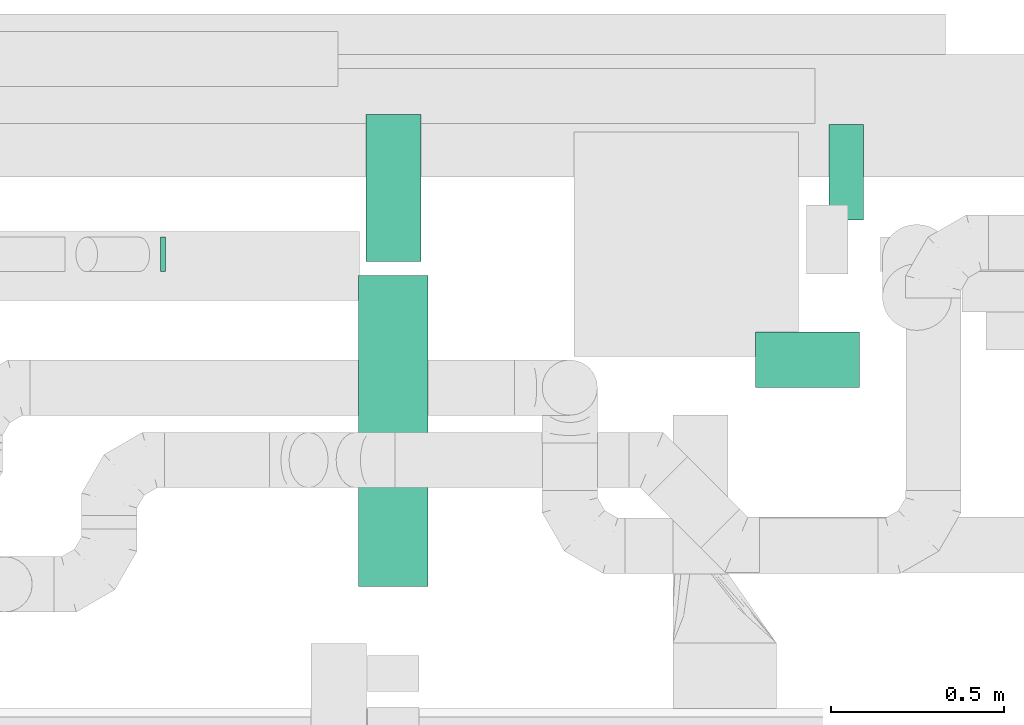
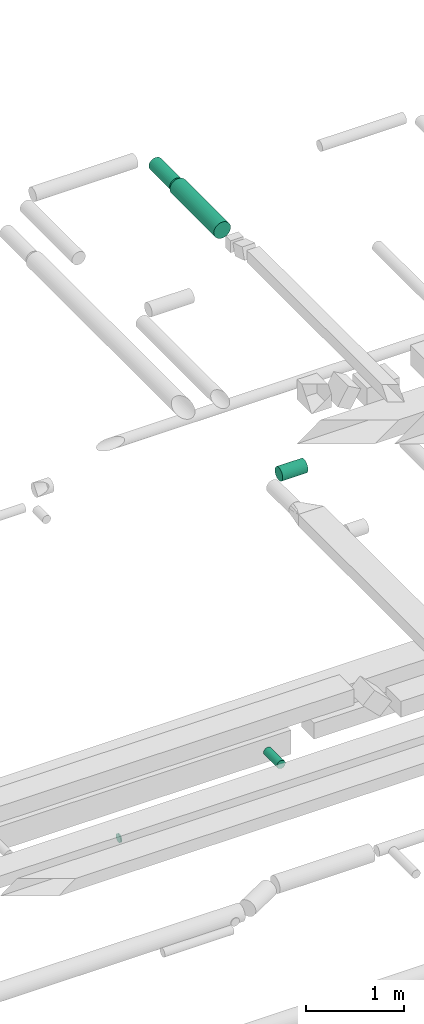
# One storey, part 286 of 337: 5 flow segments.
"""IFC2X3 building model written with IfcOpenShell, lengths in millimetres."""

import ifcopenshell
import ifcopenshell.guid

model = None  # the IFC model being written
_history = None  # IfcOwnerHistory: only IFC2X3 demands one
_inside = {}  # id of a spatial element -> (the spatial element, [elements in it])
_under = {}  # id of a project, library or spatial element -> (it, [spatial elements below it])
_declared = {}  # id of a project -> (the project, [libraries it declares])
_typed = {}  # id of a type object -> (the type object, [elements of that type])
_made_of = {}  # id of a material, layer set ... -> (it, [elements and type objects made of it])


def new_model(schema):
    """Start an empty IFC model of exactly this schema.

    Asked for "IFC4X3", IfcOpenShell would pick the latest addendum, in which some entities
    have other attributes; the version numbers below select the first issue.
    IFC2X3 requires an IfcOwnerHistory on every rooted entity: one is made here for all.
    """
    global model, _history
    if schema == "IFC4X3":
        model = ifcopenshell.file(schema_version=(4, 3, 0, 0))
    else:
        model = ifcopenshell.file(schema=schema)
    _inside.clear()
    _under.clear()
    _declared.clear()
    _typed.clear()
    _made_of.clear()
    _history = None
    if model.schema == "IFC2X3":
        org = make("IfcOrganization", Name="unknown")
        user = make(
            "IfcPersonAndOrganization",
            ThePerson=make("IfcPerson", FamilyName="unknown"),
            TheOrganization=org,
        )
        app = make(
            "IfcApplication",
            ApplicationDeveloper=org,
            Version="unknown",
            ApplicationFullName="unknown",
            ApplicationIdentifier="unknown",
        )
        _history = make(
            "IfcOwnerHistory",
            OwningUser=user,
            OwningApplication=app,
            ChangeAction="ADDED",
            CreationDate=0,
        )
    return model


def make(cls, **values):
    """One entity of the class cls with the attributes given. An attribute that is None is left unset."""
    return model.create_entity(
        cls, **{name: value for name, value in values.items() if value is not None}
    )


def entity(cls, *values):
    """Any entity or typed value of the class cls, its attributes in the order of the schema. None: left unset."""
    e = model.create_entity(cls)
    for i, value in enumerate(values):
        if value is not None:
            e[i] = value
    return e


def rooted(cls, **values):
    """An entity with a GlobalId (a new one), such as an element, a storey or a relation."""
    return make(cls, GlobalId=ifcopenshell.guid.new(), OwnerHistory=_history, **values)


def si_unit(unit_type, name, prefix=None):
    """IfcSIUnit, for example si_unit("LENGTHUNIT", "METRE", prefix="MILLI")."""
    return make("IfcSIUnit", UnitType=unit_type, Prefix=prefix, Name=name)


def converted_unit(unit_type, name, factor, base, dimensions=None, offset=None):
    """IfcConversionBasedUnit, such as the inch: factor (a typed value) times the base unit."""
    return make(
        "IfcConversionBasedUnit"
        if offset is None
        else "IfcConversionBasedUnitWithOffset",
        ConversionOffset=offset,
        Dimensions=None
        if dimensions is None
        else entity("IfcDimensionalExponents", *dimensions),
        UnitType=unit_type,
        Name=name,
        ConversionFactor=make(
            "IfcMeasureWithUnit", ValueComponent=factor, UnitComponent=base
        ),
    )


def derived_unit(unit_type, elements):
    """IfcDerivedUnit: a product of units, each with its exponent."""
    return make(
        "IfcDerivedUnit",
        Elements=[
            make("IfcDerivedUnitElement", Unit=unit, Exponent=power)
            for unit, power in elements
        ],
        UnitType=unit_type,
    )


def assignment(units):
    """IfcUnitAssignment: the units of a project."""
    return None if units is None else make("IfcUnitAssignment", Units=units)


def point(xyz):
    """IfcCartesianPoint."""
    return None if xyz is None else make("IfcCartesianPoint", Coordinates=xyz)


def direction(xyz):
    """IfcDirection."""
    return None if xyz is None else make("IfcDirection", DirectionRatios=xyz)


def frame(location, z_axis=None, x_axis=None):
    """IfcAxis2Placement3D, a coordinate frame: its origin and axes. An axis left out is left unset."""
    return make(
        "IfcAxis2Placement3D",
        Location=point(location),
        Axis=direction(z_axis),
        RefDirection=direction(x_axis),
    )


def frame_2d(location, x_axis=None):
    """IfcAxis2Placement2D, a coordinate frame in the plane: its origin and x axis."""
    return make(
        "IfcAxis2Placement2D", Location=point(location), RefDirection=direction(x_axis)
    )


def origin():
    """The frame at (0, 0, 0) with its axes left unset."""
    return frame((0.0, 0.0, 0.0))


def origin_2d_with_axis():
    """The frame at (0, 0) in the plane with the x axis (1, 0) written out."""
    return frame_2d((0.0, 0.0), x_axis=(1.0, 0.0))


def place(relative_to, where):
    """IfcLocalPlacement: puts the frame where relative to a parent placement (None: the world)."""
    return make(
        "IfcLocalPlacement", PlacementRelTo=relative_to, RelativePlacement=where
    )


def context(
    kind, dimensions, precision=None, world=None, true_north=None, identifier=None
):
    """IfcGeometricRepresentationContext, for example the 3D "Model" context."""
    return make(
        "IfcGeometricRepresentationContext",
        ContextIdentifier=identifier,
        ContextType=kind,
        CoordinateSpaceDimension=dimensions,
        Precision=precision,
        WorldCoordinateSystem=world,
        TrueNorth=true_north,
    )


def subcontext(parent, identifier, kind, view, scale=None):
    """IfcGeometricRepresentationSubContext, for example "Body" below "Model"."""
    return make(
        "IfcGeometricRepresentationSubContext",
        ContextIdentifier=identifier,
        ContextType=kind,
        ParentContext=parent,
        TargetScale=scale,
        TargetView=view,
    )


def project(units=None, contexts=None):
    """IfcProject with its units and contexts."""
    return rooted(
        "IfcProject",
        Name="project",
        RepresentationContexts=contexts,
        UnitsInContext=assignment(units),
    )


def spatial(cls, under=None, at=None, **own):
    """A site, building, storey or space (cls), placed at a placement, below another one or the project."""
    s = rooted(cls, ObjectPlacement=at, **own)
    if under is not None:
        _under.setdefault(under.id(), (under, []))[1].append(s)
    return s


def profile(cls, at=None, kind="AREA", **sizes):
    """A parametric profile (cls). Its sizes go by their IFC names, for example OverallWidth=200.0."""
    return make(cls, ProfileType=kind, Position=at, **sizes)


def circle(**sizes):
    """IfcCircleProfileDef."""
    return profile("IfcCircleProfileDef", **sizes)


def extrude(swept, where, along, depth):
    """IfcExtrudedAreaSolid: the profile swept, set in the frame where, extruded along a direction by depth."""
    return make(
        "IfcExtrudedAreaSolid",
        SweptArea=swept,
        Position=where,
        ExtrudedDirection=direction(along),
        Depth=depth,
    )


def shape(context_of_items, identifier, shape_type, items):
    """IfcShapeRepresentation: the items that make up one representation, for example the "Body"."""
    return make(
        "IfcShapeRepresentation",
        ContextOfItems=context_of_items,
        RepresentationIdentifier=identifier,
        RepresentationType=shape_type,
        Items=items,
    )


def made_of(thing, what):
    """Note that an element or type object is made of a material, layer set ...; save() writes the relation."""
    if what is not None:
        _made_of.setdefault(what.id(), (what, []))[1].append(thing)
    return thing


def type_object(cls, material=None, **own):
    """A type object (cls), such as IfcWallType, which elements share."""
    return made_of(rooted(cls, **own), material)


def element(
    cls,
    number,
    at=None,
    inside=None,
    cuts=None,
    type_object=None,
    material=None,
    context=None,
    identifier="Body",
    shape_type=None,
    held_by="IfcProductDefinitionShape",
    body=None,
    shapes=None,
    **own,
):
    """One element of the class cls, such as IfcWall. Its Tag is "e" and its number.

    at: its placement. inside: the storey or other place that contains it. cuts: it is an
    opening in that element (IfcRelVoidsElement). A single representation is given by context,
    identifier, shape_type and body (its items); several are given by shapes. held_by: the class
    of the entity that holds the representations. save() writes the other relations.
    """
    e = rooted(cls, Tag="e%d" % number, ObjectPlacement=at, **own)
    if body is not None:
        shapes = [shape(context, identifier, shape_type, body)]
    if shapes is not None:
        e.Representation = make(held_by, Representations=shapes)
    if inside is not None:
        _inside.setdefault(inside.id(), (inside, []))[1].append(e)
    if cuts is not None:
        rooted(
            "IfcRelVoidsElement", RelatingBuildingElement=cuts, RelatedOpeningElement=e
        )
    if type_object is not None:
        _typed.setdefault(type_object.id(), (type_object, []))[1].append(e)
    return made_of(e, material)


def aggregate(whole, parts):
    """IfcRelAggregates: a whole, such as a stair, and the parts it consists of."""
    return rooted("IfcRelAggregates", RelatingObject=whole, RelatedObjects=parts)


def save(model, path):
    """Write the relations noted so far, then the file.

    IfcRelAggregates (storeys below a building ...), IfcRelContainedInSpatialStructure (elements
    in a storey), IfcRelDefinesByType, IfcRelAssociatesMaterial and IfcRelDeclares: one each for
    every whole, place, type object, material and project.
    """
    for whole, parts in _under.values():
        aggregate(whole, parts)
    for where, things in _inside.values():
        rooted(
            "IfcRelContainedInSpatialStructure",
            RelatedElements=things,
            RelatingStructure=where,
        )
    for kind, things in _typed.values():
        rooted("IfcRelDefinesByType", RelatedObjects=things, RelatingType=kind)
    for what, things in _made_of.values():
        rooted("IfcRelAssociatesMaterial", RelatedObjects=things, RelatingMaterial=what)
    for by, libraries in _declared.values():
        rooted("IfcRelDeclares", RelatingContext=by, RelatedDefinitions=libraries)
    model.write(path)


model = new_model("IFC2X3")

# Units and contexts
model_context = context("Model", 3, precision=0.01, world=origin(), true_north=direction((6.12303176911189e-17, 1.0)))
body_context = subcontext(model_context, "Body", "Model", "MODEL_VIEW")
ifc_project = project(units=[si_unit("LENGTHUNIT", "METRE", prefix="MILLI"), si_unit("AREAUNIT", "SQUARE_METRE"), si_unit("VOLUMEUNIT", "CUBIC_METRE"), converted_unit("PLANEANGLEUNIT", "DEGREE", entity("IfcRatioMeasure", 0.0174532925199433), si_unit("PLANEANGLEUNIT", "RADIAN"), dimensions=[0, 0, 0, 0, 0, 0, 0]), si_unit("MASSUNIT", "GRAM", prefix="KILO"), derived_unit("MASSDENSITYUNIT", [(si_unit("MASSUNIT", "GRAM", prefix="KILO"), 1), (si_unit("LENGTHUNIT", "METRE"), -3)]), derived_unit("MOMENTOFINERTIAUNIT", [(si_unit("LENGTHUNIT", "METRE"), 4)]), si_unit("TIMEUNIT", "SECOND"), si_unit("FREQUENCYUNIT", "HERTZ"), si_unit("THERMODYNAMICTEMPERATUREUNIT", "DEGREE_CELSIUS"), derived_unit("THERMALTRANSMITTANCEUNIT", [(si_unit("MASSUNIT", "GRAM", prefix="KILO"), 1), (si_unit("THERMODYNAMICTEMPERATUREUNIT", "KELVIN"), -1), (si_unit("TIMEUNIT", "SECOND"), -3)]), derived_unit("VOLUMETRICFLOWRATEUNIT", [(si_unit("LENGTHUNIT", "METRE"), 3), (si_unit("TIMEUNIT", "SECOND"), -1)]), derived_unit("MASSFLOWRATEUNIT", [(si_unit("MASSUNIT", "GRAM", prefix="KILO"), 1), (si_unit("TIMEUNIT", "SECOND"), -1)]), derived_unit("ROTATIONALFREQUENCYUNIT", [(si_unit("TIMEUNIT", "SECOND"), -1)]), si_unit("ELECTRICCURRENTUNIT", "AMPERE"), si_unit("ELECTRICVOLTAGEUNIT", "VOLT"), si_unit("POWERUNIT", "WATT"), si_unit("FORCEUNIT", "NEWTON", prefix="KILO"), si_unit("ILLUMINANCEUNIT", "LUX"), si_unit("LUMINOUSFLUXUNIT", "LUMEN"), si_unit("LUMINOUSINTENSITYUNIT", "CANDELA"), derived_unit("USERDEFINED", [(si_unit("MASSUNIT", "GRAM", prefix="KILO"), -1), (si_unit("LENGTHUNIT", "METRE"), -2), (si_unit("TIMEUNIT", "SECOND"), 3), (si_unit("LUMINOUSFLUXUNIT", "LUMEN"), 1)]), derived_unit("LINEARVELOCITYUNIT", [(si_unit("LENGTHUNIT", "METRE"), 1), (si_unit("TIMEUNIT", "SECOND"), -1)]), si_unit("PRESSUREUNIT", "PASCAL"), derived_unit("USERDEFINED", [(si_unit("LENGTHUNIT", "METRE"), -2), (si_unit("MASSUNIT", "GRAM", prefix="KILO"), 1), (si_unit("TIMEUNIT", "SECOND"), -2)]), derived_unit("LINEARFORCEUNIT", [(si_unit("MASSUNIT", "GRAM", prefix="KILO"), 1), (si_unit("LENGTHUNIT", "METRE"), 1), (si_unit("TIMEUNIT", "SECOND"), -2), (si_unit("LENGTHUNIT", "METRE"), -1)]), derived_unit("PLANARFORCEUNIT", [(si_unit("MASSUNIT", "GRAM", prefix="KILO"), 1), (si_unit("LENGTHUNIT", "METRE"), 1), (si_unit("TIMEUNIT", "SECOND"), -2), (si_unit("LENGTHUNIT", "METRE"), -2)])], contexts=[model_context])

# Site, building, storey
site_placement = place(None, origin())
site = spatial("IfcSite", under=ifc_project, at=site_placement, CompositionType="ELEMENT")
building_placement = place(site_placement, origin())
building = spatial("IfcBuilding", under=site, at=building_placement, CompositionType="ELEMENT")
storey_placement = place(building_placement, origin())
storey = spatial("IfcBuildingStorey", under=building, at=storey_placement, CompositionType="ELEMENT", Elevation=0.0)

# Flow segments
duct_segment_type = type_object("IfcDuctSegmentType", PredefinedType="NOTDEFINED")
flow_segment_1_placement = place(storey_placement, frame((50201.22, 19353.19, 11181.63)))
element("IfcFlowSegment", 1, at=flow_segment_1_placement, inside=storey, type_object=duct_segment_type, context=body_context, shape_type="SweptSolid", body=[
    extrude(circle(Radius=50.0, at=origin_2d_with_axis()), frame((0.0, 51.6, 51.6), z_axis=(1.0, 0.0, 0.0), x_axis=(0.0, -1.0, 0.0)), (0.0, 0.0, 1.0), 14.1519282903632),
])
flow_segment_2_placement = place(storey_placement, frame((52134.31, 19504.79, 11348.4)))
element("IfcFlowSegment", 2, at=flow_segment_2_placement, inside=storey, type_object=duct_segment_type, context=body_context, shape_type="SweptSolid", body=[
    extrude(circle(Radius=50.0, at=origin_2d_with_axis()), frame((51.6, 0.0, 51.6), z_axis=(0.0, 1.0, 0.0), x_axis=(-1.0, 0.0, 0.0)), (0.0, 0.0, 1.0), 276.269796034255),
])
flow_segment_3_placement = place(storey_placement, frame((50773.32, 18443.85, 19090.32)))
element("IfcFlowSegment", 3, at=flow_segment_3_placement, inside=storey, type_object=duct_segment_type, context=body_context, shape_type="SweptSolid", body=[
    extrude(circle(Radius=100.0, at=origin_2d_with_axis()), frame((101.6, 0.0, 101.6), z_axis=(0.0, 1.0, 0.0), x_axis=(1.0, 0.0, 0.0)), (0.0, 0.0, 1.0), 899.999999999999),
])
flow_segment_4_placement = place(storey_placement, frame((50793.32, 19383.85, 19110.32)))
element("IfcFlowSegment", 4, at=flow_segment_4_placement, inside=storey, type_object=duct_segment_type, context=body_context, shape_type="SweptSolid", body=[
    extrude(circle(Radius=80.0, at=origin_2d_with_axis()), frame((81.6, 0.0, 81.6), z_axis=(0.0, 1.0, 0.0), x_axis=(1.0, 0.0, 0.0)), (0.0, 0.0, 1.0), 426.249999999998),
])
flow_segment_5_placement = place(storey_placement, frame((51923.97, 19018.35, 15293.4)))
element("IfcFlowSegment", 5, at=flow_segment_5_placement, inside=storey, type_object=duct_segment_type, context=body_context, shape_type="SweptSolid", body=[
    extrude(circle(Radius=80.0, at=origin_2d_with_axis()), frame((0.0, 81.6, 81.6), z_axis=(1.0, 0.0, 0.0), x_axis=(0.0, -1.0, 0.0)), (0.0, 0.0, 1.0), 300.00000000001),
])

save(model, "model.ifc")
